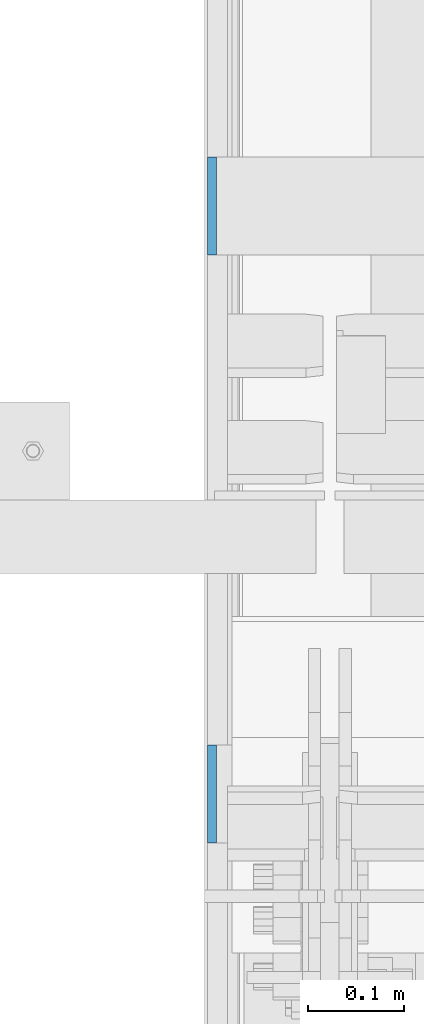
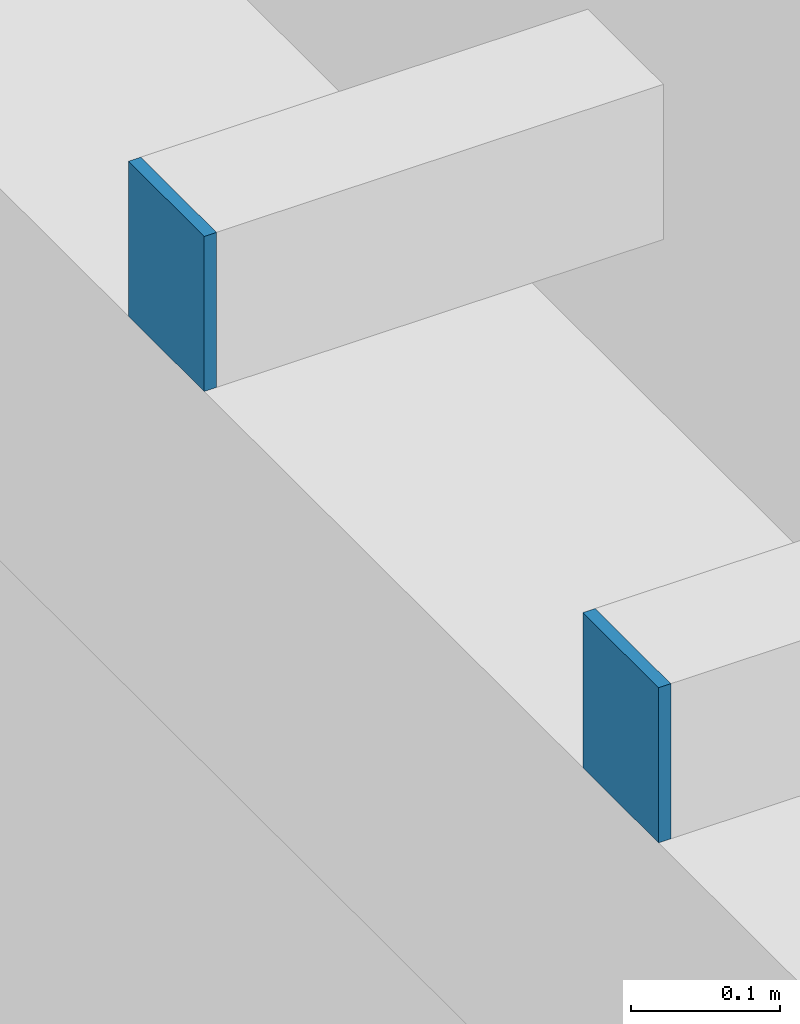
# One storey, part 438 of 1179: 2 columns, 2 elements without a shape of their own.
"""IFC2X3 building model written with IfcOpenShell, lengths in millimetres."""

from ifc_helpers import new_model, si_unit, frame, origin_with_axes, place, context, subcontext, project, spatial, faceted_brep, material, type_object, element, aggregate, save


model = new_model("IFC2X3")

# Units and contexts
model_context = context("Model", 3, precision=1e-05, world=origin_with_axes())
body_context = subcontext(model_context, "Body", "Model", "MODEL_VIEW")
ifc_project = project(units=[si_unit("LENGTHUNIT", "METRE", prefix="MILLI"), si_unit("AREAUNIT", "SQUARE_METRE"), si_unit("VOLUMEUNIT", "CUBIC_METRE"), si_unit("MASSUNIT", "GRAM", prefix="KILO"), si_unit("TIMEUNIT", "SECOND"), si_unit("PLANEANGLEUNIT", "RADIAN"), si_unit("SOLIDANGLEUNIT", "STERADIAN"), si_unit("THERMODYNAMICTEMPERATUREUNIT", "DEGREE_CELSIUS"), si_unit("LUMINOUSINTENSITYUNIT", "LUMEN")], contexts=[model_context])

# Site, building, storey
site_placement = place(None, origin_with_axes())
site = spatial("IfcSite", under=ifc_project, at=site_placement, CompositionType="ELEMENT")
building_placement = place(site_placement, origin_with_axes())
building = spatial("IfcBuilding", under=site, at=building_placement, Name="Undefined", CompositionType="ELEMENT")
storey_placement = place(building_placement, origin_with_axes())
storey = spatial("IfcBuildingStorey", under=building, at=storey_placement, Name="Undefined", CompositionType="ELEMENT", Elevation=0.0)

# Assembly, column
assembly_1_placement = place(storey_placement, origin_with_axes())
assembly_1 = element("IfcElementAssembly", 1, at=assembly_1_placement, inside=storey, Name="BEAM", AssemblyPlace="NOTDEFINED", PredefinedType="RIGID_FRAME")
ifc_material = material(Name="STEEL/A36")
column_type = type_object("IfcColumnType", PredefinedType="NOTDEFINED")
column_1_placement = place(assembly_1_placement, frame((24185.5625, 16573.5, 8013.69999998781), z_axis=(0.0, -1.0, 0.0), x_axis=(0.0, 0.0, 1.0)))
column_1 = element("IfcColumn", 2, at=column_1_placement, type_object=column_type, material=ifc_material, Name="PLATE", context=body_context, shape_type="Brep", body=[
    faceted_brep([(0.0, 4.76249999999982, -50.7999999999993), (0.0, 4.76249999999982, 50.7999999999993), (127.000000000371, 4.76249999928405, 50.8000000000002), (127.000000000371, 4.76249999928405, -50.8000000000002), (0.0, -4.76249999999982, 50.7999999999993), (127.0, -4.76250000000073, 50.7999999999993), (0.0, -4.76249999999982, -50.7999999999993), (127.0, -4.76250000000073, -50.7999999999993)], [[[0, 1, 2, 3]], [[1, 4, 5, 2]], [[4, 6, 7, 5]], [[6, 0, 3, 7]], [[5, 7, 3, 2]], [[6, 4, 1, 0]]]),
])
aggregate(assembly_1, [column_1])

assembly_2_placement = place(storey_placement, origin_with_axes())
assembly_2 = element("IfcElementAssembly", 3, at=assembly_2_placement, inside=storey, Name="BEAM", AssemblyPlace="NOTDEFINED", PredefinedType="RIGID_FRAME")
column_2_placement = place(assembly_2_placement, frame((24185.5625, 15963.9, 8013.69999998781), z_axis=(0.0, -1.0, 0.0), x_axis=(0.0, 0.0, 1.0)))
column_2 = element("IfcColumn", 4, at=column_2_placement, type_object=column_type, material=ifc_material, Name="PLATE", context=body_context, shape_type="Brep", body=[
    faceted_brep([(0.0, 4.76249999999982, -50.7999999999993), (0.0, 4.76249999999982, 50.7999999999993), (127.000000000371, 4.76249999928405, 50.8000000000002), (127.000000000371, 4.76249999928405, -50.8000000000002), (0.0, -4.76249999999982, 50.7999999999993), (127.0, -4.76250000000073, 50.7999999999993), (0.0, -4.76249999999982, -50.7999999999993), (127.0, -4.76250000000073, -50.7999999999993)], [[[0, 1, 2, 3]], [[1, 4, 5, 2]], [[4, 6, 7, 5]], [[6, 0, 3, 7]], [[5, 7, 3, 2]], [[6, 4, 1, 0]]]),
])
aggregate(assembly_2, [column_2])

save(model, "model.ifc")
